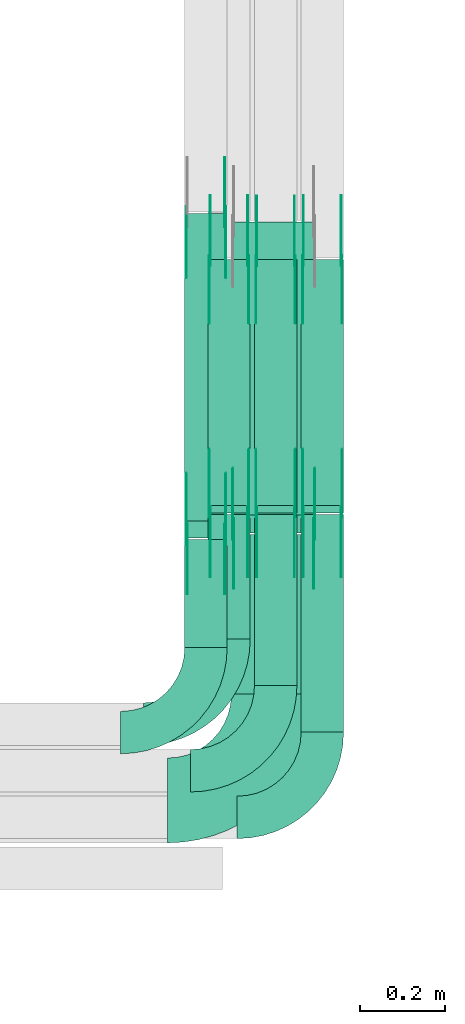
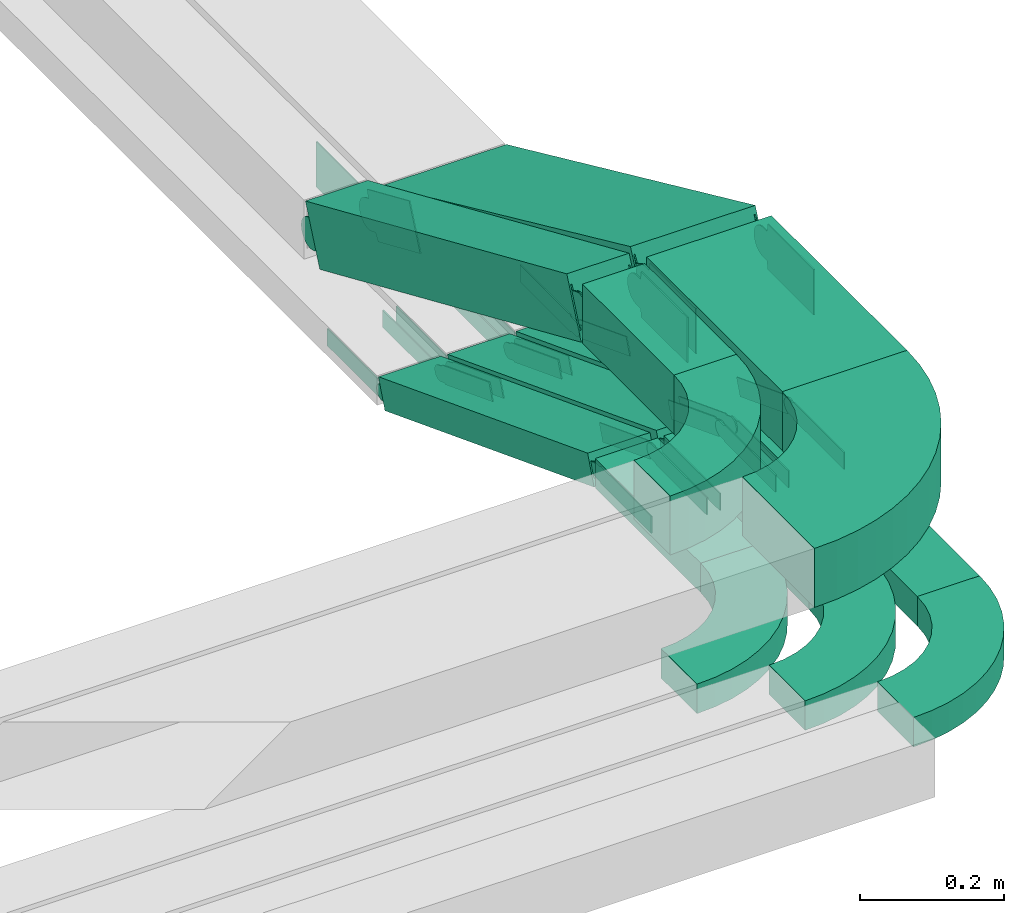
# One storey, part 18 of 23: 40 flow fittings, 10 flow segments.
"""IFC2X3 building model written with IfcOpenShell, lengths in millimetres."""

from ifc_helpers import new_model, entity, si_unit, converted_unit, derived_unit, direction, frame, frame_2d, origin, origin_2d_with_axis, place, context, subcontext, project, spatial, polyline, circle_curve, parameter, trimmed, segment, composite_curve, rectangle, outline, extrude, source, transform, mapped, material, type_object, type_shapes, element, save


model = new_model("IFC2X3")

# Units and contexts
model_context = context("Model", 3, precision=0.01, world=origin(), true_north=direction((6.12303176911189e-17, 1.0)))
body_context = subcontext(model_context, "Body", "Model", "MODEL_VIEW")
ifc_project = project(units=[si_unit("LENGTHUNIT", "METRE", prefix="MILLI"), si_unit("AREAUNIT", "SQUARE_METRE"), si_unit("VOLUMEUNIT", "CUBIC_METRE"), converted_unit("PLANEANGLEUNIT", "DEGREE", entity("IfcRatioMeasure", 0.0174532925199433), si_unit("PLANEANGLEUNIT", "RADIAN"), dimensions=[0, 0, 0, 0, 0, 0, 0]), si_unit("MASSUNIT", "GRAM", prefix="KILO"), derived_unit("MASSDENSITYUNIT", [(si_unit("MASSUNIT", "GRAM", prefix="KILO"), 1), (si_unit("LENGTHUNIT", "METRE"), -3)]), derived_unit("MOMENTOFINERTIAUNIT", [(si_unit("LENGTHUNIT", "METRE"), 4)]), si_unit("TIMEUNIT", "SECOND"), si_unit("FREQUENCYUNIT", "HERTZ"), si_unit("THERMODYNAMICTEMPERATUREUNIT", "DEGREE_CELSIUS"), derived_unit("THERMALTRANSMITTANCEUNIT", [(si_unit("MASSUNIT", "GRAM", prefix="KILO"), 1), (si_unit("THERMODYNAMICTEMPERATUREUNIT", "KELVIN"), -1), (si_unit("TIMEUNIT", "SECOND"), -3)]), derived_unit("VOLUMETRICFLOWRATEUNIT", [(si_unit("LENGTHUNIT", "METRE"), 3), (si_unit("TIMEUNIT", "SECOND"), -1)]), derived_unit("MASSFLOWRATEUNIT", [(si_unit("MASSUNIT", "GRAM", prefix="KILO"), 1), (si_unit("TIMEUNIT", "SECOND"), -1)]), derived_unit("ROTATIONALFREQUENCYUNIT", [(si_unit("TIMEUNIT", "SECOND"), -1)]), si_unit("ELECTRICCURRENTUNIT", "AMPERE"), si_unit("ELECTRICVOLTAGEUNIT", "VOLT"), si_unit("POWERUNIT", "WATT"), si_unit("FORCEUNIT", "NEWTON", prefix="KILO"), si_unit("ILLUMINANCEUNIT", "LUX"), si_unit("LUMINOUSFLUXUNIT", "LUMEN"), si_unit("LUMINOUSINTENSITYUNIT", "CANDELA"), derived_unit("USERDEFINED", [(si_unit("MASSUNIT", "GRAM", prefix="KILO"), -1), (si_unit("LENGTHUNIT", "METRE"), -2), (si_unit("TIMEUNIT", "SECOND"), 3), (si_unit("LUMINOUSFLUXUNIT", "LUMEN"), 1)]), derived_unit("LINEARVELOCITYUNIT", [(si_unit("LENGTHUNIT", "METRE"), 1), (si_unit("TIMEUNIT", "SECOND"), -1)]), si_unit("PRESSUREUNIT", "PASCAL"), derived_unit("USERDEFINED", [(si_unit("LENGTHUNIT", "METRE"), -2), (si_unit("MASSUNIT", "GRAM", prefix="KILO"), 1), (si_unit("TIMEUNIT", "SECOND"), -2)]), derived_unit("LINEARFORCEUNIT", [(si_unit("MASSUNIT", "GRAM", prefix="KILO"), 1), (si_unit("LENGTHUNIT", "METRE"), 1), (si_unit("TIMEUNIT", "SECOND"), -2), (si_unit("LENGTHUNIT", "METRE"), -1)]), derived_unit("PLANARFORCEUNIT", [(si_unit("MASSUNIT", "GRAM", prefix="KILO"), 1), (si_unit("LENGTHUNIT", "METRE"), 1), (si_unit("TIMEUNIT", "SECOND"), -2), (si_unit("LENGTHUNIT", "METRE"), -2)])], contexts=[model_context])

# Site, building, storey
site_placement = place(None, origin())
site = spatial("IfcSite", under=ifc_project, at=site_placement, CompositionType="ELEMENT")
building_placement = place(site_placement, origin())
building = spatial("IfcBuilding", under=site, at=building_placement, CompositionType="ELEMENT")
storey_placement = place(building_placement, frame((0.0, 0.0, 24000.0)))
storey = spatial("IfcBuildingStorey", under=building, at=storey_placement, CompositionType="ELEMENT", Elevation=24000.0)

# Flow segments
cable_carrier_segment_type = type_object("IfcCableCarrierSegmentType", PredefinedType="CABLETRAYSEGMENT")
flow_segment_1_placement = place(storey_placement, frame((67299.5, 1750.69, 3217.23)))
element("IfcFlowSegment", 1, at=flow_segment_1_placement, inside=storey, type_object=cable_carrier_segment_type, context=body_context, shape_type="SweptSolid", body=[
    extrude(rectangle(XDim=292.631754544286, YDim=99.9999999999946, at=origin_2d_with_axis()), frame((50.0, 146.32, 0.0), z_axis=(0.0, 0.0, 1.0), x_axis=(0.0, 1.0, 0.0)), (0.0, 0.0, 1.0), 49.9999999999973),
])
flow_segment_2_placement = place(storey_placement, frame((67409.5, 1640.69, 3217.23)))
element("IfcFlowSegment", 2, at=flow_segment_2_placement, inside=storey, type_object=cable_carrier_segment_type, context=body_context, shape_type="SweptSolid", body=[
    extrude(rectangle(XDim=402.62516769704, YDim=99.9999999999946, at=origin_2d_with_axis()), frame((50.0, 201.31, 0.0), z_axis=(0.0, 0.0, 1.0), x_axis=(0.0, 1.0, 0.0)), (0.0, 0.0, 1.0), 49.9999999999973),
])
flow_segment_3_placement = place(storey_placement, frame((67519.5, 1530.69, 3217.23)))
element("IfcFlowSegment", 3, at=flow_segment_3_placement, inside=storey, type_object=cable_carrier_segment_type, context=body_context, shape_type="SweptSolid", body=[
    extrude(rectangle(XDim=512.631754544286, YDim=99.9999999999946, at=origin_2d_with_axis()), frame((50.0, 256.32, 0.0), z_axis=(0.0, 0.0, 1.0), x_axis=(0.0, 1.0, 0.0)), (0.0, 0.0, 1.0), 49.9999999999973),
])
flow_segment_4_placement = place(storey_placement, frame((67299.5, 2046.69, 2994.01)))
element("IfcFlowSegment", 4, at=flow_segment_4_placement, inside=storey, type_object=cable_carrier_segment_type, context=body_context, shape_type="SweptSolid", body=[
    extrude(rectangle(XDim=50.0000000000003, YDim=621.842110546752, at=frame_2d((0.0, 0.0), x_axis=(0.0, 1.0))), frame((0.0, 299.27, 134.64), z_axis=(1.0, 0.0, 0.0), x_axis=(0.0, -0.933737730629972, 0.357957889140595)), (0.0, 0.0, 1.0), 99.9999999999946),
])
flow_segment_5_placement = place(storey_placement, frame((67409.5, 2046.68, 2994.02)))
element("IfcFlowSegment", 5, at=flow_segment_5_placement, inside=storey, type_object=cable_carrier_segment_type, context=body_context, shape_type="SweptSolid", body=[
    extrude(rectangle(XDim=50.0, YDim=621.102824044188, at=frame_2d((0.0, 0.0), x_axis=(0.0, 1.0))), frame((0.0, 298.88, 134.63), z_axis=(1.0, 0.0, 0.0), x_axis=(0.0, -0.933580426497182, 0.358367949545352)), (0.0, 0.0, 1.0), 99.9999999999945),
])
flow_segment_6_placement = place(storey_placement, frame((67519.5, 2046.69, 2994.01)))
element("IfcFlowSegment", 6, at=flow_segment_6_placement, inside=storey, type_object=cable_carrier_segment_type, context=body_context, shape_type="SweptSolid", body=[
    extrude(rectangle(XDim=50.0000000000004, YDim=621.842110546751, at=frame_2d((0.0, 0.0), x_axis=(0.0, 1.0))), frame((0.0, 299.27, 134.64), z_axis=(1.0, 0.0, 0.0), x_axis=(0.0, -0.933737730629971, 0.357957889140596)), (0.0, 0.0, 1.0), 99.9999999999946),
])
flow_segment_7_placement = place(storey_placement, frame((67245.11, 1730.69, 3517.23)))
element("IfcFlowSegment", 7, at=flow_segment_7_placement, inside=storey, type_object=cable_carrier_segment_type, context=body_context, shape_type="SweptSolid", body=[
    extrude(rectangle(XDim=254.10672619877, YDim=99.9999999999946, at=origin_2d_with_axis()), frame((50.0, 127.05, 0.0), z_axis=(0.0, 0.0, 1.0), x_axis=(0.0, 1.0, 0.0)), (0.0, 0.0, 1.0), 100.000000000003),
])
flow_segment_8_placement = place(storey_placement, frame((67355.11, 1620.69, 3517.23)))
element("IfcFlowSegment", 8, at=flow_segment_8_placement, inside=storey, type_object=cable_carrier_segment_type, context=body_context, shape_type="SweptSolid", body=[
    extrude(rectangle(XDim=376.244460729016, YDim=200.000000000007, at=origin_2d_with_axis()), frame((100.0, 188.12, 0.0), z_axis=(0.0, 0.0, 1.0), x_axis=(0.0, 1.0, 0.0)), (0.0, 0.0, 1.0), 100.000000000003),
])
flow_segment_9_placement = place(storey_placement, frame((67245.11, 1988.31, 3199.97)))
element("IfcFlowSegment", 9, at=flow_segment_9_placement, inside=storey, type_object=cable_carrier_segment_type, context=body_context, shape_type="SweptSolid", body=[
    extrude(rectangle(XDim=99.9999999999994, YDim=99.9999999999946, at=origin_2d_with_axis()), frame((50.0, 19.99, 362.36), z_axis=(0.0, 0.916564255602272, -0.399887440853364), x_axis=(0.0, 0.399887440853364, 0.916564255602272)), (0.0, 0.0, 1.0), 791.547372057253),
])
flow_segment_10_placement = place(storey_placement, frame((67355.11, 2000.51, 3200.72)))
element("IfcFlowSegment", 10, at=flow_segment_10_placement, inside=storey, type_object=cable_carrier_segment_type, context=body_context, shape_type="SweptSolid", body=[
    extrude(rectangle(XDim=100.000000000006, YDim=759.546206810669, at=frame_2d((0.0, 0.0), x_axis=(0.0, 1.0))), frame((0.0, 366.19, 203.34), z_axis=(1.0, 0.0, 0.0), x_axis=(0.0, -0.909506231619172, 0.415690286927532)), (0.0, 0.0, 1.0), 200.000000000006),
])

# Flow fittings
ifc_material_1 = material()
cable_carrier_fitting_type_1 = type_object("IfcCableCarrierFittingType", Name="470_DKC_S5_Variable Angle Elbow 0-45:-", PredefinedType="NOTDEFINED", material=ifc_material_1)
shared_shape_1 = source(origin(), body_context, "Body", "SweptSolid", [
    extrude(outline(composite_curve([segment(polyline([(-125.75, -225.25), (-124.75, -225.25)]), True, "CONTINUOUS"), segment(trimmed(circle_curve(frame_2d((-124.75, 124.75), x_axis=(0.0, -1.0)), 350.0), [parameter(0.0)], [parameter(90.0000000000001)], True, "PARAMETER"), True, "CONTINUOUS"), segment(polyline([(225.25, 124.75), (225.25, 125.75)]), True, "CONTINUOUS"), segment(polyline([(225.25, 125.75), (25.25, 125.75)]), True, "CONTINUOUS"), segment(polyline([(25.25, 125.75), (25.25, 124.75)]), True, "CONTINUOUS"), segment(trimmed(circle_curve(frame_2d((-124.75, 124.75), x_axis=(0.0, -1.0)), 150.0), [parameter(0.0)], [parameter(90.0000000000001)], True, "PARAMETER"), False, "CONTINUOUS"), segment(polyline([(-124.75, -25.25), (-125.75, -25.25)]), True, "CONTINUOUS"), segment(polyline([(-125.75, -25.25), (-125.75, -225.25)]), True, "CONTINUOUS")], self_intersect=False)), frame((-125.25, 125.25, -50.0)), (0.0, 0.0, 1.0), 100.0),
])
type_shapes(cable_carrier_fitting_type_1, [shared_shape_1])
flow_fitting_1_placement = place(storey_placement, frame((67455.11, 1369.69, 3567.23)))
element("IfcFlowFitting", 11, at=flow_fitting_1_placement, inside=storey, type_object=cable_carrier_fitting_type_1, material=ifc_material_1, Name="470_DKC_S5_Variable Angle Elbow 0-45:-", ObjectType="470_DKC_S5_Variable Angle Elbow 0-45:-", context=body_context, shape_type="MappedRepresentation", body=[
    mapped(shared_shape_1, transform((0.0, 0.0, 0.0), scale=1.0)),
])
cable_carrier_fitting_type_2 = type_object("IfcCableCarrierFittingType", Name="470_DKC_S5_Variable Angle Elbow 0-45:-", PredefinedType="NOTDEFINED", material=ifc_material_1)
shared_shape_2 = source(origin(), body_context, "Body", "SweptSolid", [
    extrude(outline(composite_curve([segment(polyline([(-100.75, -150.25), (-99.75, -150.25)]), True, "CONTINUOUS"), segment(trimmed(circle_curve(frame_2d((-99.75, 99.75), x_axis=(0.0, -1.0)), 250.0), [parameter(0.0)], [parameter(90.0000000000001)], True, "PARAMETER"), True, "CONTINUOUS"), segment(polyline([(150.25, 99.75), (150.25, 100.75)]), True, "CONTINUOUS"), segment(polyline([(150.25, 100.75), (50.25, 100.75)]), True, "CONTINUOUS"), segment(polyline([(50.25, 100.75), (50.25, 99.75)]), True, "CONTINUOUS"), segment(trimmed(circle_curve(frame_2d((-99.75, 99.75), x_axis=(0.0, -1.0)), 150.0), [parameter(0.0)], [parameter(90.0000000000001)], True, "PARAMETER"), False, "CONTINUOUS"), segment(polyline([(-99.75, -50.25), (-100.75, -50.25)]), True, "CONTINUOUS"), segment(polyline([(-100.75, -50.25), (-100.75, -150.25)]), True, "CONTINUOUS")], self_intersect=False)), frame((-100.25, 100.25, -25.0)), (0.0, 0.0, 1.0), 49.9999999999997),
])
type_shapes(cable_carrier_fitting_type_2, [shared_shape_2])
for number, where, name in (
    (12, (67349.5, 1549.69, 3242.23), "470_DKC_S5_Variable Angle Elbow 0-45:-"),
    (13, (67459.5, 1439.69, 3242.23), "470_DKC_S5_Variable Angle Elbow 0-45:-"),
    (14, (67569.5, 1329.69, 3242.23), "470_DKC_S5_Variable Angle Elbow 0-45:-"),
):
    element("IfcFlowFitting", number, at=place(storey_placement, frame(where)), inside=storey, type_object=cable_carrier_fitting_type_2, material=ifc_material_1, Name=name, ObjectType="470_DKC_S5_Variable Angle Elbow 0-45:-", context=body_context, shape_type="MappedRepresentation", body=[
        mapped(shared_shape_2, transform((0.0, 0.0, 0.0), scale=1.0)),
    ])
ifc_material_2 = material(Name="G")
cable_carrier_fitting_type_3 = type_object("IfcCableCarrierFittingType", PredefinedType="NOTDEFINED", material=ifc_material_2)
shared_shape_3 = source(origin(), body_context, "Body", "SweptSolid", [
    extrude(outline(composite_curve([segment(trimmed(circle_curve(frame_2d((-44.59, 0.0), x_axis=(1.0, 0.0)), 12.5), [parameter(90.0000000000007)], [parameter(270.0)], True, "PARAMETER"), True, "CONTINUOUS"), segment(polyline([(-44.59, -12.5), (-33.09, -12.5)]), True, "CONTINUOUS"), segment(polyline([(-33.09, -12.5), (-31.23, -14.5)]), True, "CONTINUOUS"), segment(polyline([(-31.23, -14.5), (108.91, -14.5)]), True, "CONTINUOUS"), segment(polyline([(108.91, -14.5), (108.91, 14.5)]), True, "CONTINUOUS"), segment(polyline([(108.91, 14.5), (-31.23, 14.5)]), True, "CONTINUOUS"), segment(polyline([(-31.23, 14.5), (-33.09, 12.5)]), True, "CONTINUOUS"), segment(polyline([(-33.09, 12.5), (-44.59, 12.5)]), True, "CONTINUOUS")], self_intersect=False)), frame((44.59, 0.0, 0.0), z_axis=(0.0, 0.0, -1.0), x_axis=(1.0, 0.0, 0.0)), (0.0, 0.0, -1.0), 2.0),
])
type_shapes(cable_carrier_fitting_type_3, [shared_shape_3])
flow_fitting_2_placement = place(storey_placement, frame((67414.04, 2641.44, 3015.08), z_axis=(-1.0, 0.0, 0.0), x_axis=(0.0, -0.933580426497204, 0.358367949545295)))
element("IfcFlowFitting", 15, at=flow_fitting_2_placement, inside=storey, type_object=cable_carrier_fitting_type_3, material=ifc_material_2, context=body_context, shape_type="MappedRepresentation", body=[
    mapped(shared_shape_3, transform((0.0, 0.0, 0.0), scale=1.0)),
])
cable_carrier_fitting_type_4 = type_object("IfcCableCarrierFittingType", PredefinedType="NOTDEFINED", material=ifc_material_2)
type_shapes(cable_carrier_fitting_type_4, [shared_shape_3])
flow_fitting_3_placement = place(storey_placement, frame((67502.96, 2641.44, 3015.08), z_axis=(1.0, 0.0, 0.0), x_axis=(0.0, 1.0, 0.0)))
element("IfcFlowFitting", 16, at=flow_fitting_3_placement, inside=storey, type_object=cable_carrier_fitting_type_4, material=ifc_material_2, context=body_context, shape_type="MappedRepresentation", body=[
    mapped(shared_shape_3, transform((0.0, 0.0, 0.0), scale=1.0)),
])
flow_fitting_4_placement = place(storey_placement, frame((67414.04, 2049.69, 3242.23), z_axis=(-1.0, 0.0, 0.0), x_axis=(0.0, 0.933580426497204, -0.358367949545295)))
element("IfcFlowFitting", 17, at=flow_fitting_4_placement, inside=storey, type_object=cable_carrier_fitting_type_3, material=ifc_material_2, context=body_context, shape_type="MappedRepresentation", body=[
    mapped(shared_shape_3, transform((0.0, 0.0, 0.0), scale=1.0)),
])
flow_fitting_5_placement = place(storey_placement, frame((67502.96, 2049.69, 3242.23), z_axis=(1.0, 0.0, 0.0), x_axis=(0.0, -1.0, 0.0)))
element("IfcFlowFitting", 18, at=flow_fitting_5_placement, inside=storey, type_object=cable_carrier_fitting_type_4, material=ifc_material_2, context=body_context, shape_type="MappedRepresentation", body=[
    mapped(shared_shape_3, transform((0.0, 0.0, 0.0), scale=1.0)),
])
flow_fitting_6_placement = place(storey_placement, frame((67304.04, 2642.22, 3015.08), z_axis=(-1.0, 0.0, 0.0), x_axis=(0.0, -0.93373773062991, 0.357957889140756)))
element("IfcFlowFitting", 19, at=flow_fitting_6_placement, inside=storey, type_object=cable_carrier_fitting_type_3, material=ifc_material_2, context=body_context, shape_type="MappedRepresentation", body=[
    mapped(shared_shape_3, transform((0.0, 0.0, 0.0), scale=1.0)),
])
flow_fitting_7_placement = place(storey_placement, frame((67392.96, 2642.22, 3015.08), z_axis=(1.0, 0.0, 0.0), x_axis=(0.0, 1.0, 0.0)))
element("IfcFlowFitting", 20, at=flow_fitting_7_placement, inside=storey, type_object=cable_carrier_fitting_type_4, material=ifc_material_2, context=body_context, shape_type="MappedRepresentation", body=[
    mapped(shared_shape_3, transform((0.0, 0.0, 0.0), scale=1.0)),
])
flow_fitting_8_placement = place(storey_placement, frame((67304.04, 2049.69, 3242.23), z_axis=(-1.0, 0.0, 0.0), x_axis=(0.0, 0.93373773062991, -0.357957889140756)))
element("IfcFlowFitting", 21, at=flow_fitting_8_placement, inside=storey, type_object=cable_carrier_fitting_type_3, material=ifc_material_2, context=body_context, shape_type="MappedRepresentation", body=[
    mapped(shared_shape_3, transform((0.0, 0.0, 0.0), scale=1.0)),
])
flow_fitting_9_placement = place(storey_placement, frame((67392.96, 2049.69, 3242.23), z_axis=(1.0, 0.0, 0.0), x_axis=(0.0, -1.0, 0.0)))
element("IfcFlowFitting", 22, at=flow_fitting_9_placement, inside=storey, type_object=cable_carrier_fitting_type_4, material=ifc_material_2, context=body_context, shape_type="MappedRepresentation", body=[
    mapped(shared_shape_3, transform((0.0, 0.0, 0.0), scale=1.0)),
])
flow_fitting_10_placement = place(storey_placement, frame((67524.04, 2642.22, 3015.08), z_axis=(-1.0, 0.0, 0.0), x_axis=(0.0, -0.93373773062991, 0.357957889140756)))
element("IfcFlowFitting", 23, at=flow_fitting_10_placement, inside=storey, type_object=cable_carrier_fitting_type_3, material=ifc_material_2, context=body_context, shape_type="MappedRepresentation", body=[
    mapped(shared_shape_3, transform((0.0, 0.0, 0.0), scale=1.0)),
])
flow_fitting_11_placement = place(storey_placement, frame((67612.96, 2642.22, 3015.08), z_axis=(1.0, 0.0, 0.0), x_axis=(0.0, 1.0, 0.0)))
element("IfcFlowFitting", 24, at=flow_fitting_11_placement, inside=storey, type_object=cable_carrier_fitting_type_4, material=ifc_material_2, context=body_context, shape_type="MappedRepresentation", body=[
    mapped(shared_shape_3, transform((0.0, 0.0, 0.0), scale=1.0)),
])
flow_fitting_12_placement = place(storey_placement, frame((67524.04, 2049.69, 3242.23), z_axis=(-1.0, 0.0, 0.0), x_axis=(0.0, 0.93373773062991, -0.357957889140756)))
element("IfcFlowFitting", 25, at=flow_fitting_12_placement, inside=storey, type_object=cable_carrier_fitting_type_3, material=ifc_material_2, context=body_context, shape_type="MappedRepresentation", body=[
    mapped(shared_shape_3, transform((0.0, 0.0, 0.0), scale=1.0)),
])
flow_fitting_13_placement = place(storey_placement, frame((67612.96, 2049.69, 3242.23), z_axis=(1.0, 0.0, 0.0), x_axis=(0.0, -1.0, 0.0)))
element("IfcFlowFitting", 26, at=flow_fitting_13_placement, inside=storey, type_object=cable_carrier_fitting_type_4, material=ifc_material_2, context=body_context, shape_type="MappedRepresentation", body=[
    mapped(shared_shape_3, transform((0.0, 0.0, 0.0), scale=1.0)),
])
cable_carrier_fitting_type_5 = type_object("IfcCableCarrierFittingType", PredefinedType="NOTDEFINED", material=ifc_material_2)
shared_shape_4 = source(origin(), body_context, "Body", "SweptSolid", [
    extrude(outline(composite_curve([segment(trimmed(circle_curve(frame_2d((-44.59, 0.0), x_axis=(1.0, 0.0)), 12.5), [parameter(90.0000000000007)], [parameter(270.0)], True, "PARAMETER"), True, "CONTINUOUS"), segment(polyline([(-44.59, -12.5), (-33.09, -12.5)]), True, "CONTINUOUS"), segment(polyline([(-33.09, -12.5), (-31.23, -14.5)]), True, "CONTINUOUS"), segment(polyline([(-31.23, -14.5), (108.91, -14.5)]), True, "CONTINUOUS"), segment(polyline([(108.91, -14.5), (108.91, 14.5)]), True, "CONTINUOUS"), segment(polyline([(108.91, 14.5), (-31.23, 14.5)]), True, "CONTINUOUS"), segment(polyline([(-31.23, 14.5), (-33.09, 12.5)]), True, "CONTINUOUS"), segment(polyline([(-33.09, 12.5), (-44.59, 12.5)]), True, "CONTINUOUS")], self_intersect=False)), frame((44.59, 0.0, 0.0)), (0.0, 0.0, 1.0), 2.0),
])
type_shapes(cable_carrier_fitting_type_5, [shared_shape_4])
flow_fitting_14_placement = place(storey_placement, frame((67504.96, 2641.44, 3015.08), z_axis=(1.0, 0.0, 0.0), x_axis=(0.0, -0.933580426497204, 0.358367949545295)))
element("IfcFlowFitting", 27, at=flow_fitting_14_placement, inside=storey, type_object=cable_carrier_fitting_type_5, material=ifc_material_2, context=body_context, shape_type="MappedRepresentation", body=[
    mapped(shared_shape_4, transform((0.0, 0.0, 0.0), scale=1.0)),
])
cable_carrier_fitting_type_6 = type_object("IfcCableCarrierFittingType", PredefinedType="NOTDEFINED", material=ifc_material_2)
type_shapes(cable_carrier_fitting_type_6, [shared_shape_4])
flow_fitting_15_placement = place(storey_placement, frame((67416.04, 2641.44, 3015.08), z_axis=(-1.0, 0.0, 0.0), x_axis=(0.0, 1.0, 0.0)))
element("IfcFlowFitting", 28, at=flow_fitting_15_placement, inside=storey, type_object=cable_carrier_fitting_type_6, material=ifc_material_2, context=body_context, shape_type="MappedRepresentation", body=[
    mapped(shared_shape_4, transform((0.0, 0.0, 0.0), scale=1.0)),
])
flow_fitting_16_placement = place(storey_placement, frame((67504.96, 2049.69, 3242.23), z_axis=(1.0, 0.0, 0.0), x_axis=(0.0, 0.933580426497204, -0.358367949545295)))
element("IfcFlowFitting", 29, at=flow_fitting_16_placement, inside=storey, type_object=cable_carrier_fitting_type_5, material=ifc_material_2, context=body_context, shape_type="MappedRepresentation", body=[
    mapped(shared_shape_4, transform((0.0, 0.0, 0.0), scale=1.0)),
])
flow_fitting_17_placement = place(storey_placement, frame((67416.04, 2049.69, 3242.23), z_axis=(-1.0, 0.0, 0.0), x_axis=(0.0, -1.0, 0.0)))
element("IfcFlowFitting", 30, at=flow_fitting_17_placement, inside=storey, type_object=cable_carrier_fitting_type_6, material=ifc_material_2, context=body_context, shape_type="MappedRepresentation", body=[
    mapped(shared_shape_4, transform((0.0, 0.0, 0.0), scale=1.0)),
])
flow_fitting_18_placement = place(storey_placement, frame((67394.96, 2642.22, 3015.08), z_axis=(1.0, 0.0, 0.0), x_axis=(0.0, -0.93373773062991, 0.357957889140756)))
element("IfcFlowFitting", 31, at=flow_fitting_18_placement, inside=storey, type_object=cable_carrier_fitting_type_5, material=ifc_material_2, context=body_context, shape_type="MappedRepresentation", body=[
    mapped(shared_shape_4, transform((0.0, 0.0, 0.0), scale=1.0)),
])
flow_fitting_19_placement = place(storey_placement, frame((67306.04, 2642.22, 3015.08), z_axis=(-1.0, 0.0, 0.0), x_axis=(0.0, 1.0, 0.0)))
element("IfcFlowFitting", 32, at=flow_fitting_19_placement, inside=storey, type_object=cable_carrier_fitting_type_6, material=ifc_material_2, context=body_context, shape_type="MappedRepresentation", body=[
    mapped(shared_shape_4, transform((0.0, 0.0, 0.0), scale=1.0)),
])
flow_fitting_20_placement = place(storey_placement, frame((67394.96, 2049.69, 3242.23), z_axis=(1.0, 0.0, 0.0), x_axis=(0.0, 0.93373773062991, -0.357957889140756)))
element("IfcFlowFitting", 33, at=flow_fitting_20_placement, inside=storey, type_object=cable_carrier_fitting_type_5, material=ifc_material_2, context=body_context, shape_type="MappedRepresentation", body=[
    mapped(shared_shape_4, transform((0.0, 0.0, 0.0), scale=1.0)),
])
flow_fitting_21_placement = place(storey_placement, frame((67306.04, 2049.69, 3242.23), z_axis=(-1.0, 0.0, 0.0), x_axis=(0.0, -1.0, 0.0)))
element("IfcFlowFitting", 34, at=flow_fitting_21_placement, inside=storey, type_object=cable_carrier_fitting_type_6, material=ifc_material_2, context=body_context, shape_type="MappedRepresentation", body=[
    mapped(shared_shape_4, transform((0.0, 0.0, 0.0), scale=1.0)),
])
flow_fitting_22_placement = place(storey_placement, frame((67614.96, 2642.22, 3015.08), z_axis=(1.0, 0.0, 0.0), x_axis=(0.0, -0.93373773062991, 0.357957889140756)))
element("IfcFlowFitting", 35, at=flow_fitting_22_placement, inside=storey, type_object=cable_carrier_fitting_type_5, material=ifc_material_2, context=body_context, shape_type="MappedRepresentation", body=[
    mapped(shared_shape_4, transform((0.0, 0.0, 0.0), scale=1.0)),
])
flow_fitting_23_placement = place(storey_placement, frame((67526.04, 2642.22, 3015.08), z_axis=(-1.0, 0.0, 0.0), x_axis=(0.0, 1.0, 0.0)))
element("IfcFlowFitting", 36, at=flow_fitting_23_placement, inside=storey, type_object=cable_carrier_fitting_type_6, material=ifc_material_2, context=body_context, shape_type="MappedRepresentation", body=[
    mapped(shared_shape_4, transform((0.0, 0.0, 0.0), scale=1.0)),
])
flow_fitting_24_placement = place(storey_placement, frame((67614.96, 2049.69, 3242.23), z_axis=(1.0, 0.0, 0.0), x_axis=(0.0, 0.93373773062991, -0.357957889140756)))
element("IfcFlowFitting", 37, at=flow_fitting_24_placement, inside=storey, type_object=cable_carrier_fitting_type_5, material=ifc_material_2, context=body_context, shape_type="MappedRepresentation", body=[
    mapped(shared_shape_4, transform((0.0, 0.0, 0.0), scale=1.0)),
])
flow_fitting_25_placement = place(storey_placement, frame((67526.04, 2049.69, 3242.23), z_axis=(-1.0, 0.0, 0.0), x_axis=(0.0, -1.0, 0.0)))
element("IfcFlowFitting", 38, at=flow_fitting_25_placement, inside=storey, type_object=cable_carrier_fitting_type_6, material=ifc_material_2, context=body_context, shape_type="MappedRepresentation", body=[
    mapped(shared_shape_4, transform((0.0, 0.0, 0.0), scale=1.0)),
])
cable_carrier_fitting_type_7 = type_object("IfcCableCarrierFittingType", Name="470_DKC_S5_Variable Angle Elbow 0-45:-", PredefinedType="NOTDEFINED", material=ifc_material_1)
shared_shape_5 = source(origin(), body_context, "Body", "SweptSolid", [
    extrude(outline(composite_curve([segment(polyline([(-100.75, -150.25), (-99.75, -150.25)]), True, "CONTINUOUS"), segment(trimmed(circle_curve(frame_2d((-99.75, 99.75), x_axis=(0.0, -1.0)), 250.0), [parameter(0.0)], [parameter(90.0000000000001)], True, "PARAMETER"), True, "CONTINUOUS"), segment(polyline([(150.25, 99.75), (150.25, 100.75)]), True, "CONTINUOUS"), segment(polyline([(150.25, 100.75), (50.25, 100.75)]), True, "CONTINUOUS"), segment(polyline([(50.25, 100.75), (50.25, 99.75)]), True, "CONTINUOUS"), segment(trimmed(circle_curve(frame_2d((-99.75, 99.75), x_axis=(0.0, -1.0)), 150.0), [parameter(0.0)], [parameter(90.0000000000001)], True, "PARAMETER"), False, "CONTINUOUS"), segment(polyline([(-99.75, -50.25), (-100.75, -50.25)]), True, "CONTINUOUS"), segment(polyline([(-100.75, -50.25), (-100.75, -150.25)]), True, "CONTINUOUS")], self_intersect=False)), frame((-100.25, 100.25, -50.0)), (0.0, 0.0, 1.0), 100.0),
])
type_shapes(cable_carrier_fitting_type_7, [shared_shape_5])
flow_fitting_26_placement = place(storey_placement, frame((67295.11, 1529.69, 3567.23)))
element("IfcFlowFitting", 39, at=flow_fitting_26_placement, inside=storey, type_object=cable_carrier_fitting_type_7, material=ifc_material_1, Name="470_DKC_S5_Variable Angle Elbow 0-45:-", ObjectType="470_DKC_S5_Variable Angle Elbow 0-45:-", context=body_context, shape_type="MappedRepresentation", body=[
    mapped(shared_shape_5, transform((0.0, 0.0, 0.0), scale=1.0)),
])
cable_carrier_fitting_type_8 = type_object("IfcCableCarrierFittingType", PredefinedType="NOTDEFINED", material=ifc_material_2)
shared_shape_6 = source(origin(), body_context, "Body", "SweptSolid", [
    extrude(outline(composite_curve([segment(trimmed(circle_curve(frame_2d((-41.47, 0.0), x_axis=(1.0, 0.0)), 25.0), [parameter(90.0000000000007)], [parameter(270.0)], True, "PARAMETER"), True, "CONTINUOUS"), segment(polyline([(-41.47, -25.0), (-29.97, -25.0)]), True, "CONTINUOUS"), segment(polyline([(-29.97, -25.0), (-28.1, -38.5)]), True, "CONTINUOUS"), segment(polyline([(-28.1, -38.5), (99.53, -38.5)]), True, "CONTINUOUS"), segment(polyline([(99.53, -38.5), (99.53, 38.5)]), True, "CONTINUOUS"), segment(polyline([(99.53, 38.5), (-28.1, 38.5)]), True, "CONTINUOUS"), segment(polyline([(-28.1, 38.5), (-29.97, 25.0)]), True, "CONTINUOUS"), segment(polyline([(-29.97, 25.0), (-41.47, 25.0)]), True, "CONTINUOUS")], self_intersect=False)), frame((41.47, 0.0, 0.0), z_axis=(0.0, 0.0, -1.0), x_axis=(1.0, 0.0, 0.0)), (0.0, 0.0, -1.0), 2.0),
])
type_shapes(cable_carrier_fitting_type_8, [shared_shape_6])
flow_fitting_27_placement = place(storey_placement, frame((67249.65, 2745.06, 3240.89), z_axis=(-1.0, 0.0, 0.0), x_axis=(0.0, -0.916564255602269, 0.399887440853372)))
element("IfcFlowFitting", 40, at=flow_fitting_27_placement, inside=storey, type_object=cable_carrier_fitting_type_8, material=ifc_material_2, context=body_context, shape_type="MappedRepresentation", body=[
    mapped(shared_shape_6, transform((0.0, 0.0, 0.0), scale=1.0)),
])
cable_carrier_fitting_type_9 = type_object("IfcCableCarrierFittingType", PredefinedType="NOTDEFINED", material=ifc_material_2)
type_shapes(cable_carrier_fitting_type_9, [shared_shape_6])
flow_fitting_28_placement = place(storey_placement, frame((67338.57, 2745.06, 3240.89), z_axis=(1.0, 0.0, 0.0), x_axis=(0.0, 1.0, 0.0)))
element("IfcFlowFitting", 41, at=flow_fitting_28_placement, inside=storey, type_object=cable_carrier_fitting_type_9, material=ifc_material_2, context=body_context, shape_type="MappedRepresentation", body=[
    mapped(shared_shape_6, transform((0.0, 0.0, 0.0), scale=1.0)),
])
flow_fitting_29_placement = place(storey_placement, frame((67249.65, 1997.07, 3567.23), z_axis=(-1.0, 0.0, 0.0), x_axis=(0.0, 0.916564255602269, -0.399887440853372)))
element("IfcFlowFitting", 42, at=flow_fitting_29_placement, inside=storey, type_object=cable_carrier_fitting_type_8, material=ifc_material_2, context=body_context, shape_type="MappedRepresentation", body=[
    mapped(shared_shape_6, transform((0.0, 0.0, 0.0), scale=1.0)),
])
flow_fitting_30_placement = place(storey_placement, frame((67338.57, 1997.07, 3567.23), z_axis=(1.0, 0.0, 0.0), x_axis=(0.0, -1.0, 0.0)))
element("IfcFlowFitting", 43, at=flow_fitting_30_placement, inside=storey, type_object=cable_carrier_fitting_type_9, material=ifc_material_2, context=body_context, shape_type="MappedRepresentation", body=[
    mapped(shared_shape_6, transform((0.0, 0.0, 0.0), scale=1.0)),
])
flow_fitting_31_placement = place(storey_placement, frame((67359.65, 2009.69, 3567.23), z_axis=(-1.0, 0.0, 0.0), x_axis=(0.0, 0.909506231619165, -0.415690286927545)))
element("IfcFlowFitting", 44, at=flow_fitting_31_placement, inside=storey, type_object=cable_carrier_fitting_type_8, material=ifc_material_2, context=body_context, shape_type="MappedRepresentation", body=[
    mapped(shared_shape_6, transform((0.0, 0.0, 0.0), scale=1.0)),
])
flow_fitting_32_placement = place(storey_placement, frame((67548.57, 2009.69, 3567.23), z_axis=(1.0, 0.0, 0.0), x_axis=(0.0, -1.0, 0.0)))
element("IfcFlowFitting", 45, at=flow_fitting_32_placement, inside=storey, type_object=cable_carrier_fitting_type_9, material=ifc_material_2, context=body_context, shape_type="MappedRepresentation", body=[
    mapped(shared_shape_6, transform((0.0, 0.0, 0.0), scale=1.0)),
])
cable_carrier_fitting_type_10 = type_object("IfcCableCarrierFittingType", PredefinedType="NOTDEFINED", material=ifc_material_2)
shared_shape_7 = source(origin(), body_context, "Body", "SweptSolid", [
    extrude(outline(composite_curve([segment(trimmed(circle_curve(frame_2d((-41.47, 0.0), x_axis=(1.0, 0.0)), 25.0), [parameter(90.0000000000007)], [parameter(270.0)], True, "PARAMETER"), True, "CONTINUOUS"), segment(polyline([(-41.47, -25.0), (-29.97, -25.0)]), True, "CONTINUOUS"), segment(polyline([(-29.97, -25.0), (-28.1, -38.5)]), True, "CONTINUOUS"), segment(polyline([(-28.1, -38.5), (99.53, -38.5)]), True, "CONTINUOUS"), segment(polyline([(99.53, -38.5), (99.53, 38.5)]), True, "CONTINUOUS"), segment(polyline([(99.53, 38.5), (-28.1, 38.5)]), True, "CONTINUOUS"), segment(polyline([(-28.1, 38.5), (-29.97, 25.0)]), True, "CONTINUOUS"), segment(polyline([(-29.97, 25.0), (-41.47, 25.0)]), True, "CONTINUOUS")], self_intersect=False)), frame((41.47, 0.0, 0.0)), (0.0, 0.0, 1.0), 2.0),
])
type_shapes(cable_carrier_fitting_type_10, [shared_shape_7])
for number, where, z_axis, x_axis in (
    (46, (67340.57, 2745.06, 3240.89), (1.0, 0.0, 0.0), (0.0, -0.916564255602269, 0.399887440853372)),
    (47, (67340.57, 1997.07, 3567.23), (1.0, 0.0, 0.0), (0.0, 0.916564255602269, -0.399887440853372)),
):
    element("IfcFlowFitting", number, at=place(storey_placement, frame(where, z_axis=z_axis, x_axis=x_axis)), inside=storey, type_object=cable_carrier_fitting_type_10, material=ifc_material_2, context=body_context, shape_type="MappedRepresentation", body=[
        mapped(shared_shape_7, transform((0.0, 0.0, 0.0), scale=1.0)),
    ])
cable_carrier_fitting_type_11 = type_object("IfcCableCarrierFittingType", PredefinedType="NOTDEFINED", material=ifc_material_2)
type_shapes(cable_carrier_fitting_type_11, [shared_shape_7])
flow_fitting_33_placement = place(storey_placement, frame((67251.65, 1997.07, 3567.23), z_axis=(-1.0, 0.0, 0.0), x_axis=(0.0, -1.0, 0.0)))
element("IfcFlowFitting", 48, at=flow_fitting_33_placement, inside=storey, type_object=cable_carrier_fitting_type_11, material=ifc_material_2, context=body_context, shape_type="MappedRepresentation", body=[
    mapped(shared_shape_7, transform((0.0, 0.0, 0.0), scale=1.0)),
])
flow_fitting_34_placement = place(storey_placement, frame((67550.57, 2009.69, 3567.23), z_axis=(1.0, 0.0, 0.0), x_axis=(0.0, 0.909506231619165, -0.415690286927545)))
element("IfcFlowFitting", 49, at=flow_fitting_34_placement, inside=storey, type_object=cable_carrier_fitting_type_10, material=ifc_material_2, context=body_context, shape_type="MappedRepresentation", body=[
    mapped(shared_shape_7, transform((0.0, 0.0, 0.0), scale=1.0)),
])
flow_fitting_35_placement = place(storey_placement, frame((67361.65, 2009.69, 3567.23), z_axis=(-1.0, 0.0, 0.0), x_axis=(0.0, -1.0, 0.0)))
element("IfcFlowFitting", 50, at=flow_fitting_35_placement, inside=storey, type_object=cable_carrier_fitting_type_11, material=ifc_material_2, context=body_context, shape_type="MappedRepresentation", body=[
    mapped(shared_shape_7, transform((0.0, 0.0, 0.0), scale=1.0)),
])

save(model, "model.ifc")
